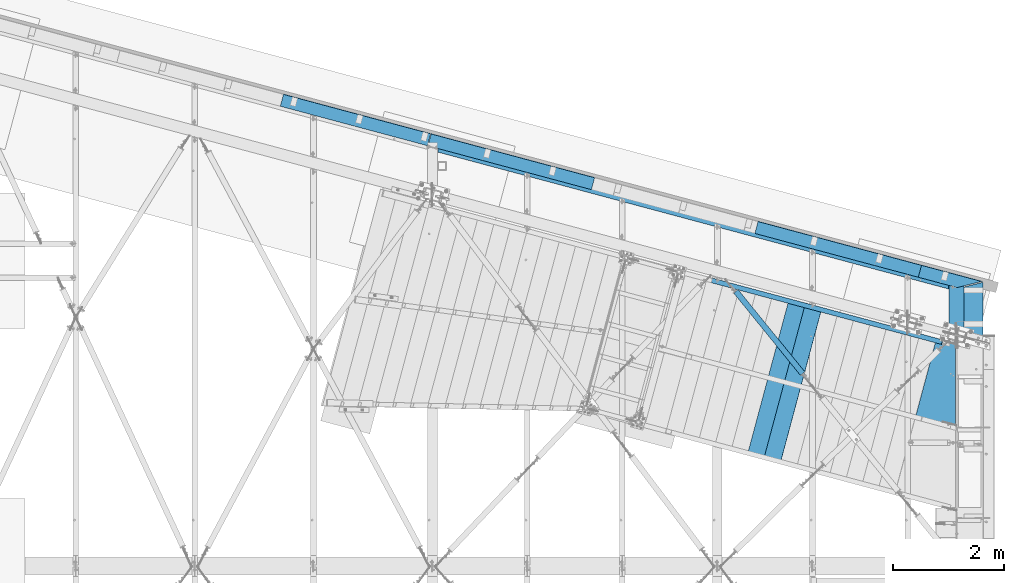
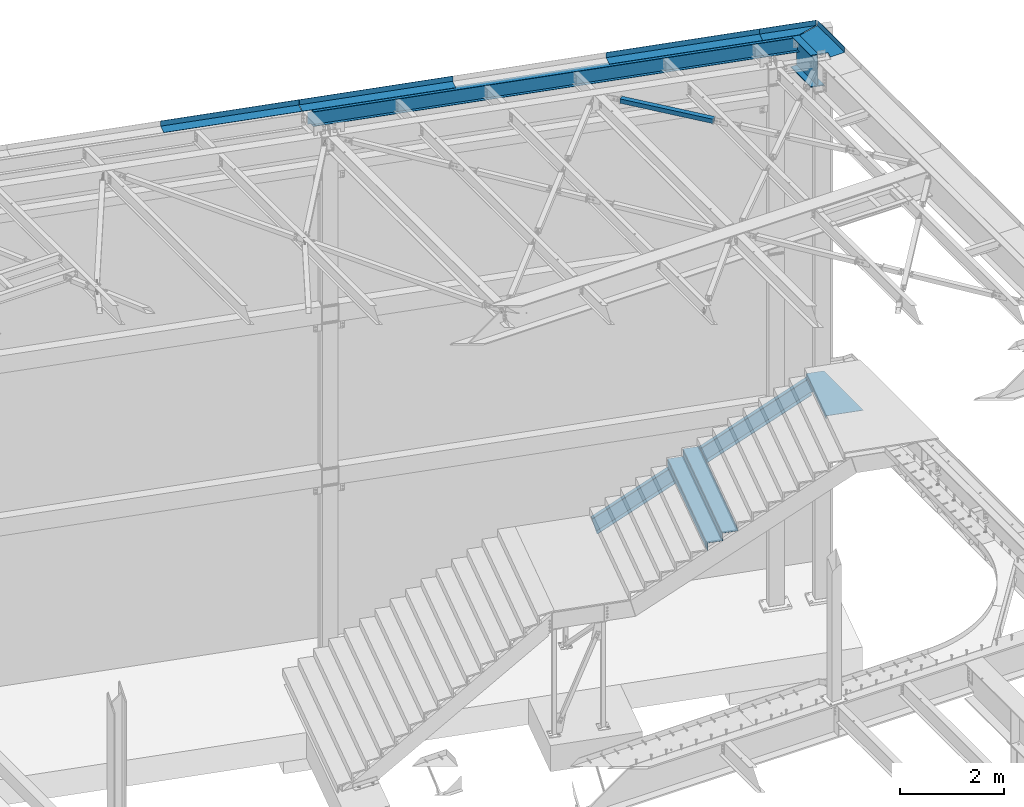
# One storey, part 1175 of 1763: 11 beams, 1 member, 6 elements without a shape of their own.
"""IFC2X3 building model written with IfcOpenShell, lengths in millimetres."""

from ifc_helpers import new_model, si_unit, frame, origin_with_axes, place, context, subcontext, project, spatial, faceted_brep, material, type_object, element, aggregate, save


model = new_model("IFC2X3")

# Units and contexts
model_context = context("Model", 3, precision=1e-05, world=origin_with_axes())
body_context = subcontext(model_context, "Body", "Model", "MODEL_VIEW")
ifc_project = project(units=[si_unit("LENGTHUNIT", "METRE", prefix="MILLI"), si_unit("AREAUNIT", "SQUARE_METRE"), si_unit("VOLUMEUNIT", "CUBIC_METRE"), si_unit("MASSUNIT", "GRAM", prefix="KILO"), si_unit("TIMEUNIT", "SECOND"), si_unit("PLANEANGLEUNIT", "RADIAN"), si_unit("SOLIDANGLEUNIT", "STERADIAN"), si_unit("THERMODYNAMICTEMPERATUREUNIT", "DEGREE_CELSIUS"), si_unit("LUMINOUSINTENSITYUNIT", "LUMEN")], contexts=[model_context])

# Site, building, storey
site_placement = place(None, origin_with_axes())
site = spatial("IfcSite", under=ifc_project, at=site_placement, CompositionType="ELEMENT")
building_placement = place(site_placement, origin_with_axes())
building = spatial("IfcBuilding", under=site, at=building_placement, Name="Undefined", CompositionType="ELEMENT")
storey_placement = place(building_placement, origin_with_axes())
storey = spatial("IfcBuildingStorey", under=building, at=storey_placement, Name="Undefined", CompositionType="ELEMENT", Elevation=0.0)

# Assembly, beam
assembly_1_placement = place(storey_placement, origin_with_axes())
assembly_1 = element("IfcElementAssembly", 1, at=assembly_1_placement, inside=storey, Name="BENT_PLATE", AssemblyPlace="NOTDEFINED", PredefinedType="RIGID_FRAME")
ifc_material_1 = material(Name="STEEL/A36")
beam_type_1 = type_object("IfcBeamType", PredefinedType="NOTDEFINED")
beam_1_placement = place(assembly_1_placement, frame((-20623.570463063, 60669.7976540184, 5251.44988278029), z_axis=(-0.258865912030778, -0.965913267114844, 3.00823476209188e-08), x_axis=(0.0, 0.0, -1.0)))
beam_1 = element("IfcBeam", 2, at=beam_1_placement, type_object=beam_type_1, material=ifc_material_1, Name="BENT_PLATE", context=body_context, shape_type="Brep", body=[
    faceted_brep([(57.6506588334341, -1650.94322731794, 733.41037240727), (47.6245708971892, -1650.94377090204, 733.410372253653), (47.6251633835427, -1650.9296699886, -733.439627678781), (57.6501641560826, -1650.9302135683, -733.439627534848), (121.443393857227, -1650.93021355403, -733.439649048218), (121.443888534568, -1650.94322730369, 733.410350893893), (121.443393855133, -1641.40521355441, -733.43956454334), (121.443888532473, -1641.41822730406, 733.410435398764), (57.650164153988, -1641.40521356867, -733.439543029977), (57.1501641539899, -1641.40466998691, -733.439539326588), (57.1495716676363, -1641.41877090035, 733.410460605854), (57.6506588313387, -1641.41822731832, 733.410456912134), (57.1496311080928, -906.560219858533, 733.416980199065), (47.6246311080931, -906.560220968502, 733.416976351727), (47.6251917954878, -1299.67460055151, -733.436511378146), (57.1501917954874, -1299.67459944154, -733.436507530809)], [[[0, 1, 2, 3, 4, 5]], [[5, 4, 6, 7]], [[8, 9, 10, 11, 7, 6]], [[1, 0, 5, 7, 11, 10, 12, 13]], [[2, 1, 13, 14]], [[9, 8, 6, 4, 3, 2, 14, 15]], [[10, 9, 15, 12]], [[14, 13, 12, 15]]]),
])
aggregate(assembly_1, [beam_1])

assembly_2_placement = place(storey_placement, origin_with_axes())
assembly_2 = element("IfcElementAssembly", 3, at=assembly_2_placement, inside=storey, Name="H. BRACE", AssemblyPlace="NOTDEFINED", PredefinedType="RIGID_FRAME")
ifc_material_2 = material()
beam_type_2 = type_object("IfcBeamType", Name="HSS4X4X3/8", PredefinedType="NOTDEFINED")
beam_2_placement = place(assembly_2_placement, frame((-24264.6496174484, 60949.8198631699, 12371.3875), z_axis=(0.0, 0.0, 1.0), x_axis=(-0.630211709758953, 0.776423338702989, 0.0)))
beam_2 = element("IfcBeam", 4, at=beam_2_placement, type_object=beam_type_2, material=ifc_material_2, Name="H. BRACE", ObjectType="HSS4X4X3/8", context=body_context, shape_type="Brep", body=[
    faceted_brep([(281.348620558478, 41.2749999993139, -41.2749999999996), (281.348620558667, -41.2750000006235, -41.2749999999996), (2189.29465645863, -41.2750000050546, -41.2749999999996), (2189.29465645843, 41.2749999948828, -41.2749999999996), (281.348620558667, -41.2750000006235, 41.2749999999996), (2189.29465645863, -41.2750000050546, 41.2749999999996), (281.348620558478, 41.2749999993139, 41.2749999999996), (2189.29465645843, 41.2749999948828, 41.2749999999996), (281.348620558456, 50.7999999993044, -50.7999999999993), (281.348620558456, 50.7999999993044, 50.7999999999993), (2189.29465645842, 50.7999999948806, 50.7999999999993), (2189.29465645842, 50.7999999948806, -50.7999999999993), (281.348620558689, -50.8000000006214, 50.7999999999993), (2189.29465645865, -50.8000000050415, 50.7999999999993), (281.348620558689, -50.8000000006214, -50.7999999999993), (2189.29465645865, -50.8000000050415, -50.7999999999993)], [[[0, 1, 2, 3]], [[1, 4, 5, 2]], [[4, 6, 7, 5]], [[6, 0, 3, 7]], [[8, 9, 10, 11]], [[9, 12, 13, 10]], [[12, 14, 15, 13]], [[14, 8, 11, 15]], [[13, 15, 11, 10], [5, 7, 3, 2]], [[14, 12, 9, 8], [6, 4, 1, 0]]]),
])
aggregate(assembly_2, [beam_2])

assembly_3_placement = place(storey_placement, origin_with_axes())
assembly_3 = element("IfcElementAssembly", 5, at=assembly_3_placement, inside=storey, Name="BEAM", AssemblyPlace="NOTDEFINED", PredefinedType="RIGID_FRAME")
ifc_material_3 = material(Name="STEEL/A992")
beam_type_3 = type_object("IfcBeamType", Name="W14X22", PredefinedType="NOTDEFINED")
beam_3_placement = place(assembly_3_placement, frame((-31117.2521174484, 65250.3763135178, 12271.375), z_axis=(0.0, 0.0, 1.0), x_axis=(0.965925826295336, -0.25881904507913, 0.0)))
beam_3 = element("IfcBeam", 6, at=beam_3_placement, type_object=beam_type_3, material=ifc_material_3, Name="BEAM", ObjectType="W14X22", context=body_context, shape_type="Brep", body=[
    faceted_brep([(25.5084291125531, -3.17499999995198, -142.874999999674), (25.5084291125531, 3.17500000006112, -142.874999999678), (96.1209962971625, 3.17500000019936, -142.874999999793), (97.8224736689081, -3.17499999981374, -142.874999999793), (101.152520857038, 3.17500000021391, -143.841729922387), (102.853998228791, -3.17499999981374, -143.841729922387), (105.418041413563, 3.17500000021391, -146.594743822867), (107.119518785308, -3.17499999979918, -146.594743822867), (108.268171129035, 3.17500000022847, -150.714920291017), (109.969648500781, -3.17499999979191, -150.714920291017), (109.269003590765, 3.17500000022119, -155.574999809058), (110.970480962511, -3.17499999979191, -155.574999809058), (127.134515994061, -63.4999999999491, -166.6875), (110.970480962176, -3.17499999978463, -166.6875), (109.269003590394, 3.17500000022847, -166.6875), (93.1049685585167, 63.5000000003856, -166.6875), (93.1049685585167, 63.5000000003856, -174.625), (127.134515994061, -63.4999999999491, -174.625), (9613.90070710065, 63.5000000184446, 166.6875), (9630.06474213253, 3.17500001828739, 166.6875), (109.269003591246, 3.17500000022847, 166.6875), (93.1049685593607, 63.5000000003856, 166.6875), (97.8224736687698, -3.17499999982101, 139.699999999804), (96.1209962970315, 3.17500000019936, 139.699999999804), (25.5084291125531, 3.17500000006112, 139.699999999919), (25.5084291125531, -3.17499999995198, 139.699999999923), (102.85399822866, -3.17499999980646, 140.666729922386), (101.152520856922, 3.17500000020664, 140.666729922386), (107.119518785199, -3.17499999979191, 143.419743822862), (105.418041413453, 3.17500000022119, 143.419743822862), (109.969648500686, -3.17499999979918, 147.539920291019), (108.268171128933, 3.17500000022119, 147.539920291019), (110.970480962424, -3.17499999979191, 152.399999809069), (109.269003590678, 3.17500000022119, 152.399999809069), (9647.93025453619, -63.4999999818901, 174.625), (9613.90070710065, 63.5000000184446, 174.625), (93.1049685593607, 63.5000000003856, 174.625), (127.134515994905, -63.4999999999491, 174.625), (9647.93025453619, -63.4999999818901, 166.6875), (127.134515994905, -63.4999999999491, 166.6875), (9631.76621950431, -3.17499998173298, 166.6875), (110.97048096302, -3.17499999978463, 166.6875), (9631.76621950499, -3.17499998174026, 141.287499820201), (9630.06474213324, 3.17500001828012, 141.287499820201), (9632.76705196672, -3.17499998173298, 136.427420302154), (9631.06557459498, 3.17500001828739, 136.427420302154), (9635.6171816822, -3.1749999817257, 132.307243834), (9633.91570431045, 3.17500001828739, 132.307243834), (9639.88270223873, -3.17499998171843, 129.554229933523), (9638.18122486698, 3.17500001829467, 129.554229933523), (9644.91422679861, -3.17499998170388, 128.587500010935), (9643.21274942686, 3.17500001830922, 128.587500010935), (9761.60279988415, -3.1749999814856, 128.587500010935), (9759.9013225124, 3.1750000185275, 128.587500010935), (9761.60279988415, -3.1749999814856, -166.6875), (9777.76683491575, -63.49999998165, -166.6875), (9777.76683491575, -63.49999998165, -174.625), (9743.7372874808, 63.5000000186919, -174.625), (9743.7372874808, 63.5000000186919, -166.6875), (9759.9013225124, 3.1750000185275, -166.6875)], [[[0, 1, 2, 3]], [[3, 2, 4, 5]], [[5, 4, 6, 7]], [[7, 6, 8, 9]], [[9, 8, 10, 11]], [[12, 13, 11, 10, 14, 15, 16, 17]], [[18, 19, 20, 21]], [[22, 23, 24, 25]], [[26, 27, 23, 22]], [[28, 29, 27, 26]], [[30, 31, 29, 28]], [[32, 33, 31, 30]], [[34, 35, 36, 37]], [[38, 34, 37, 39]], [[40, 38, 39, 41]], [[37, 36, 21, 20, 33, 32, 41, 39]], [[35, 18, 21, 36]], [[34, 38, 40, 42, 43, 19, 18, 35]], [[44, 45, 43, 42]], [[46, 47, 45, 44]], [[48, 49, 47, 46]], [[50, 51, 49, 48]], [[52, 53, 51, 50]], [[54, 55, 56, 57, 58, 59, 53, 52]], [[56, 55, 12, 17]], [[57, 56, 17, 16]], [[58, 57, 16, 15]], [[59, 58, 15, 14]], [[6, 4, 2, 1, 24, 23, 27, 29, 31, 33, 20, 19, 43, 45, 47, 49, 51, 53, 59, 14, 10, 8]], [[25, 24, 1, 0]], [[54, 52, 50, 48, 46, 44, 42, 40, 41, 32, 30, 28, 26, 22, 25, 0, 3, 5, 7, 9, 11, 13]], [[55, 54, 13, 12]]]),
])

assembly_4_placement = place(storey_placement, origin_with_axes())
assembly_4 = element("IfcElementAssembly", 7, at=assembly_4_placement, inside=storey, Name="BEAM", AssemblyPlace="NOTDEFINED", PredefinedType="RIGID_FRAME")
beam_type_4 = type_object("IfcBeamType", PredefinedType="NOTDEFINED")
beam_4_placement = place(assembly_4_placement, frame((-32525.426175196, 65627.6954150612, 12449.175), z_axis=(-0.965925827679309, 0.258819039914073, 0.0), x_axis=(0.258819045079128, 0.965925826295336, 0.0)))
beam_4 = element("IfcBeam", 8, at=beam_4_placement, type_object=beam_type_4, material=ifc_material_1, Name="BENT_PLATE", context=body_context, shape_type="Brep", body=[
    faceted_brep([(-1.38752511702478e-08, -3.17499999999927, -1372.58549999819), (1.38898030854762e-08, -3.17499999999927, 1372.5854999982), (1.38898030854762e-08, 3.17499999999927, 1372.5854999982), (-1.38752511702478e-08, 3.17499999999927, -1372.58549999819), (228.599995019147, 3.17499999999745, 1372.58549999529), (228.599994931385, 3.17499999999745, -1372.58550000109), (222.249994931357, -3.17500000000109, -1372.58550000101), (222.249995019134, -3.17500000000109, 1372.58549999537), (228.599994989214, -123.82500003836, 1372.58549999258), (228.599994961318, -123.824999978362, -1372.5855000038), (222.249994989194, -123.82500003836, 1372.58549999267), (222.249994961297, -123.824999978362, -1372.58550000371)], [[[0, 1, 2, 3]], [[3, 2, 4, 5]], [[1, 0, 6, 7]], [[5, 4, 8, 9]], [[4, 2, 1, 7, 10, 8]], [[7, 6, 11, 10]], [[6, 0, 3, 5, 9, 11]], [[10, 11, 9, 8]]]),
])
aggregate(assembly_4, [beam_4])

# Beam
beam_5_placement = place(assembly_3_placement, frame((-29718.6799716604, 64875.6300365378, 12449.175), z_axis=(-0.965925827679309, 0.258819039914073, 0.0), x_axis=(0.258819045079128, 0.965925826295336, 0.0)))
beam_5 = element("IfcBeam", 9, at=beam_5_placement, type_object=beam_type_4, material=ifc_material_1, Name="BENT_PLATE", context=body_context, shape_type="Brep", body=[
    faceted_brep([(0.0, -3.17499999999927, -1523.99999999999), (0.0, -3.17499999999927, 1524.0), (0.0, 3.17499999999927, 1524.0), (0.0, 3.17499999999927, -1523.99999999999), (228.599995165183, 3.17499993969795, 1523.99999998704), (228.599994834185, 3.17499994154787, -1524.00000000063), (222.249995293445, -3.17500005680085, -1524.00000000046), (222.249995624443, -3.17500005865077, 1523.99999998722), (228.599994977769, -123.824999999819, 1524.000000004), (228.599994986405, -123.824999999819, -1524.00000000269), (222.249994977741, -123.824999999819, 1524.00000000397), (222.249994986378, -123.824999999819, -1524.00000000271)], [[[0, 1, 2, 3]], [[3, 2, 4, 5]], [[1, 0, 6, 7]], [[5, 4, 8, 9]], [[4, 2, 1, 7, 10, 8]], [[7, 6, 11, 10]], [[6, 0, 3, 5, 9, 11]], [[10, 11, 9, 8]]]),
])

beam_6_placement = place(assembly_3_placement, frame((-21808.4801090702, 62756.098371606, 12449.175), z_axis=(-0.965925827679309, 0.258819039914073, 0.0), x_axis=(0.258819045079128, 0.965925826295336, 0.0)))
beam_6 = element("IfcBeam", 10, at=beam_6_placement, type_object=beam_type_4, material=ifc_material_1, Name="BENT_PLATE", context=body_context, shape_type="Brep", body=[
    faceted_brep([(228.59999498049, 3.17499999999927, 569.241499998789), (-3.34694050252438e-10, 3.17499999999927, 569.24149999924), (-3.34694050252438e-10, -3.17499999999927, 569.24149999924), (222.24999498047, -3.17499999999927, 569.241499998803), (222.249994979131, -123.825000004876, 569.241499998505), (228.599994979151, -123.825000004876, 569.241499998483), (228.599994979755, -123.825000002138, -564.310996623106), (228.599994978409, 3.17499999999927, -564.310996620698), (8.00355337560177e-11, 3.17499999999927, -151.54164795929), (8.00355337560177e-11, -3.17499999999927, -151.54164795929), (222.249994978418, -3.17499999999927, -552.845181128236), (222.249994979727, -123.825000002165, -552.8451811306)], [[[0, 1, 2, 3, 4, 5]], [[0, 5, 6, 7]], [[1, 0, 7, 8]], [[2, 1, 8, 9]], [[3, 2, 9, 10]], [[4, 3, 10, 11]], [[5, 4, 11, 6]], [[10, 9, 8, 7, 6, 11]]]),
])

beam_7_placement = place(assembly_3_placement, frame((-23830.3961345848, 63297.8691377512, 12449.175), z_axis=(-0.965925827679309, 0.258819039914073, 0.0), x_axis=(0.258819045079128, 0.965925826295336, 0.0)))
beam_7 = element("IfcBeam", 11, at=beam_7_placement, type_object=beam_type_4, material=ifc_material_1, Name="BENT_PLATE", context=body_context, shape_type="Brep", body=[
    faceted_brep([(0.0, -3.17499999999927, -1523.99999999999), (0.0, -3.17499999999927, 1524.0), (0.0, 3.17499999999927, 1524.0), (0.0, 3.17499999999927, -1523.99999999999), (228.599995165183, 3.17499993969795, 1523.99999998704), (228.599994834185, 3.17499994154787, -1524.00000000063), (222.249995293445, -3.17500005680085, -1524.00000000046), (222.249995624443, -3.17500005865077, 1523.99999998722), (228.599994977769, -123.824999999819, 1524.000000004), (228.599994986405, -123.824999999819, -1524.00000000269), (222.249994977741, -123.824999999819, 1524.00000000397), (222.249994986378, -123.824999999819, -1524.00000000271)], [[[0, 1, 2, 3]], [[3, 2, 4, 5]], [[1, 0, 6, 7]], [[5, 4, 8, 9]], [[4, 2, 1, 7, 10, 8]], [[7, 6, 11, 10]], [[6, 0, 3, 5, 9, 11]], [[10, 11, 9, 8]]]),
])

aggregate(assembly_3, [beam_5, beam_6, beam_7, beam_3])

# Assembly, beam
assembly_5_placement = place(storey_placement, origin_with_axes())
assembly_5 = element("IfcElementAssembly", 12, at=assembly_5_placement, inside=storey, Name="BEAM", AssemblyPlace="NOTDEFINED", PredefinedType="RIGID_FRAME")
beam_type_5 = type_object("IfcBeamType", PredefinedType="NOTDEFINED")
beam_8_placement = place(assembly_5_placement, frame((-21657.3396174484, 62294.5421055503, 12449.1750000081), z_axis=(0.0, -1.0, 0.0), x_axis=(1.0, 0.0, 0.0)))
beam_8 = element("IfcBeam", 13, at=beam_8_placement, type_object=beam_type_5, material=ifc_material_1, Name="BENT_PLATE", context=body_context, shape_type="Brep", body=[
    faceted_brep([(182.720654144166, -3.17500000807013, 370.866916913903), (182.720654144166, 3.17499999999927, 370.866916913903), (0.0, 3.17499999999927, 321.897562840262), (0.0, -3.17499999999927, 321.897562840262), (142.803059551425, -3.17499999999927, 519.8125), (142.803059551425, 3.17499999999927, 519.8125), (466.725006103516, -3.17499999999927, 519.8125), (466.725006103516, 123.825000000001, 519.8125), (460.375006103517, 123.825000000001, 519.8125), (460.375006103517, 3.17499999999927, 519.8125), (466.725006103516, -3.17499999999927, -519.8125), (466.725006103516, 123.825000000001, -519.8125), (460.375006103517, 123.825000000001, -518.28232777401), (460.375006103517, 3.17499999999927, -518.28232777401), (0.0, 3.17499999999927, -403.680835359948), (0.0, -3.17499999999927, -403.680835359948)], [[[0, 1, 2, 3]], [[4, 5, 1, 0]], [[6, 7, 8, 9, 5, 4]], [[7, 6, 10, 11]], [[8, 7, 11, 12]], [[9, 8, 12, 13]], [[2, 1, 5, 9, 13, 14]], [[3, 2, 14, 15]], [[6, 4, 0, 3, 15, 10]], [[14, 13, 12, 11, 10, 15]]]),
])

# Assembly, member
assembly_6_placement = place(storey_placement, origin_with_axes())
assembly_6 = element("IfcElementAssembly", 14, at=assembly_6_placement, inside=storey, Name="STRINGER", AssemblyPlace="NOTDEFINED", PredefinedType="RIGID_FRAME")
member_type = type_object("IfcMemberType", Name="C15X33.9", PredefinedType="NOTDEFINED")
member_placement = place(assembly_6_placement, frame((-21831.0065570277, 61708.2782716226, 5029.75011938), z_axis=(0.486695708763338, -0.13043503320458, -0.863778900636194), x_axis=(-0.834335499956352, 0.223602912988303, -0.50387102597364)))
member = element("IfcMember", 15, at=member_placement, type_object=member_type, material=ifc_material_1, Name="STRINGER", ObjectType="C15X33.9", context=body_context, shape_type="Brep", body=[
    faceted_brep([(5093.86808868585, -40.0966168740488, -181.305096367927), (5093.86808870259, 33.3374999864391, -181.30509636792), (5097.17557359672, 33.33749998641, -169.070972498997), (5184.86027757211, -42.862500014875, 190.500000000771), (5191.54668042265, -42.8625000148677, 181.765892500778), (5191.89944326302, -40.0966168751911, 181.30509636971), (5191.89944327977, 33.3374999852967, 181.305096369717), (5184.86027759157, 42.532403616402, 190.500000000782), (5081.85725439498, 42.5324036176025, -190.499999998985), (5081.51530759058, 42.8624999865206, -190.499999998981), (5184.51833078719, 42.86249998532, 190.500000000782), (5188.59195838564, 33.3374999853477, 169.070972500795), (5093.2661741679, -42.8625000137181, -181.765892498999), (5081.85725437552, -42.8625000136672, -190.499999998996), (9.52499993769015, -42.8624999996755, -190.499999999876), (2.8385970806994, -42.8624999996682, -181.765892499883), (2.48583423947275, -40.0966168460727, -181.305096366494), (2.48583425621473, 33.3375000004962, -181.30509636649), (9.52499995716062, 42.532403633908, -190.499999999869), (5.79331913747228, 33.3375000004598, -169.070972499889), (86.9230119693748, 33.3374999995067, 131.021317260747), (97.2097035880579, 33.3374999993976, 169.070972499907), (103.003022770456, 33.3374999986409, 190.499999999894), (112.8699695746, 42.8624999993117, 190.499999999894), (9.86694675921899, 42.8625000005195, -190.499999999869), (252.228013597647, 33.337499998961, 169.070972499932), (252.228013597676, 33.3374999977386, 190.499999979631), (252.228013597967, -42.862500002404, 190.499999999534), (252.228013597956, -42.8625000012398, 181.765892499916)], [[[0, 1, 2]], [[3, 4, 5, 6, 7]], [[1, 8, 9, 10, 7, 6, 11, 2]], [[0, 12, 13, 8, 1]], [[14, 15, 16, 17, 18]], [[19, 20, 21, 22, 23, 24, 18, 17]], [[22, 21, 25, 26]], [[27, 26, 25, 28]], [[27, 28, 4, 3]], [[28, 25, 11, 5, 4]], [[2, 19, 16, 15, 12, 0]], [[15, 14, 13, 12]], [[13, 14, 18, 24, 9, 8]], [[24, 23, 10, 9]], [[5, 11, 6]], [[25, 21, 20, 19, 2, 11]], [[19, 17, 16]], [[10, 23, 22, 26, 27, 3, 7]]]),
])

# Beam
beam_type_6 = type_object("IfcBeamType", Name="W30X90", PredefinedType="NOTDEFINED")
beam_9_placement = place(assembly_5_placement, frame((-21670.0396174484, 61857.7142211422, 12071.35), z_axis=(0.0, 0.0, 1.0), x_axis=(0.0, 1.0, 0.0)))
beam_9 = element("IfcBeam", 16, at=beam_9_placement, type_object=beam_type_6, material=ifc_material_3, Name="BEAM", ObjectType="W30X90", context=body_context, shape_type="Brep", body=[
    faceted_brep([(125.913804920681, 6.34999999999854, -358.775), (122.510189710942, -6.34999999999854, -358.775), (142.091642277403, -6.34999999999854, -358.775), (145.495257482522, 6.34999999999854, -358.775), (153.231514021696, -6.34999999999854, -349.250000017137), (156.635129226815, 6.34999999999854, -349.250000025268), (156.038440255397, -6.34999999999854, -346.849975395311), (159.442055460517, 6.34999999999854, -346.849975403444), (157.443157200156, -6.34999999999854, -345.365293715493), (160.846772405275, 6.34999999999854, -345.365293723624), (158.493804238766, -6.34999999999854, -343.62880521505), (161.897419443892, 6.34999999999854, -343.628805223181), (159.143535047639, -6.34999999999854, -341.717936564621), (162.547150252765, 6.34999999999854, -341.717936572752), (152.905861028063, 6.34999999999854, -330.200000027971), (149.502245822943, -6.34999999999854, -330.20000001984), (116.631798419519, -6.34999999999854, -330.200000405674), (120.035413624639, 6.34999999999854, -330.200000413806), (156.679553328358, 6.34999999999854, -330.92504736714), (153.275938123239, -6.34999999999854, -330.925047359009), (159.87873523499, 6.34999999999854, -332.98980759456), (156.475120029871, -6.34999999999854, -332.989807586428), (162.016360330425, 6.34999999999854, -336.079939700187), (158.612745125298, -6.34999999999854, -336.079939692056), (162.766994589168, 6.34999999999854, -339.717889717285), (159.363379384049, -6.34999999999854, -339.717889709154), (932.232303561796, -131.762500000001, 374.65), (932.232303561796, 131.762500000001, 374.65), (159.52450469655, 131.762500000001, 374.650000008056), (88.8994890945251, -131.762500000001, 374.65), (83.0210982686403, -131.762500000001, 358.775), (108.480942126807, -131.762500000001, 358.775), (932.232303561796, -131.762500000001, 358.775), (79.7343844080533, -131.762500000001, 358.775), (116.631798419236, -6.34999999999854, 358.775), (142.091642277403, -6.34999999999854, 358.775), (932.232303561796, -6.34999999999854, 358.775), (113.345084558729, -6.34999999999854, 358.775), (932.232303561796, -131.762500000001, -374.65), (932.232303561796, -131.762500000001, -358.775), (108.480942126807, -131.762500000001, -358.775), (88.8994895147989, -131.762500000001, -358.775), (79.7343844080533, -131.762500000001, -374.65), (932.232303561796, 131.762500000001, -374.65), (150.359399914545, 131.762500000001, -374.65), (179.105957633117, 131.762500000001, -358.774999297637), (932.232303561796, 131.762500000001, -358.775), (159.524505116824, 131.762500000001, -358.774999279374), (932.232303561796, 6.34999999999854, -358.775), (932.232303561796, 6.34999999999854, 358.775), (932.232303561796, 131.762500000001, 358.775), (932.232303561796, -6.34999999999854, -358.775), (179.105957633117, 131.762500000001, 358.775), (153.64611377495, 131.762500000001, 358.775), (150.359399914545, 131.762500000001, 358.775), (116.748699763863, 6.34999999999854, 358.775), (145.495257482522, 6.34999999999854, 358.774988175401), (120.035413624355, 6.34999999999854, 358.774987792742), (156.635129226815, 6.34999999999854, 349.250000015953), (153.231514021696, -6.34999999999854, 349.250000007822), (159.442055460517, 6.34999999999854, 346.849975394129), (156.038440255397, -6.34999999999854, 346.849975385996), (160.846772405275, 6.34999999999854, 345.365293714309), (157.443157200156, -6.34999999999854, 345.365293706178), (161.897419443892, 6.34999999999854, 343.628805213866), (158.493804238766, -6.34999999999854, 343.628805205735), (162.547150252765, 6.34999999999854, 341.717936563437), (159.143535047639, -6.34999999999854, 341.717936555306), (162.766994589168, 6.34999999999854, 339.71788970797), (159.363379384049, -6.34999999999854, 339.717889699839), (162.016360330425, 6.34999999999854, 336.079939690871), (158.612745125298, -6.34999999999854, 336.079939682741), (159.87873523499, 6.34999999999854, 332.989807585245), (156.475120029871, -6.34999999999854, 332.989807577113), (156.679553328358, 6.34999999999854, 330.925047357825), (153.275938123239, -6.34999999999854, 330.925047349694), (152.905861028063, 6.34999999999854, 330.200000018656), (149.502245822943, -6.34999999999854, 330.200000010525), (120.03541362437, 6.34999999999854, 330.200000404491), (116.631798419243, -6.34999999999854, 330.20000039636)], [[[0, 1, 2, 3]], [[3, 2, 4, 5]], [[5, 4, 6, 7]], [[7, 6, 8, 9]], [[9, 8, 10, 11]], [[11, 10, 12, 13]], [[14, 15, 16, 17]], [[18, 19, 15, 14]], [[20, 21, 19, 18]], [[22, 23, 21, 20]], [[24, 25, 23, 22]], [[13, 12, 25, 24]], [[26, 27, 28, 29]], [[30, 31, 32, 26, 29, 33]], [[34, 35, 36, 32, 31, 30, 33, 37]], [[38, 39, 40, 41, 42]], [[43, 38, 42, 44]], [[45, 46, 43, 44, 47]], [[48, 49, 50, 27, 26, 32, 36, 51, 39, 38, 43, 46]], [[27, 50, 52, 53, 54, 28]], [[33, 29, 28, 54, 55, 37]], [[53, 52, 50, 49, 56, 57, 55, 54]], [[37, 55, 57, 34]], [[56, 35, 34, 57]], [[58, 59, 35, 56]], [[60, 61, 59, 58]], [[62, 63, 61, 60]], [[64, 65, 63, 62]], [[66, 67, 65, 64]], [[68, 69, 67, 66]], [[70, 71, 69, 68]], [[72, 73, 71, 70]], [[74, 75, 73, 72]], [[76, 77, 75, 74]], [[78, 79, 77, 76]], [[79, 78, 17, 16]], [[10, 8, 6, 4, 2, 51, 36, 35, 59, 61, 63, 65, 67, 69, 71, 73, 75, 77, 79, 16, 15, 19, 21, 23, 25, 12]], [[40, 39, 51, 2, 1, 41]], [[47, 44, 42, 41, 1, 0]], [[3, 48, 46, 45, 47, 0]], [[20, 18, 14, 17, 78, 76, 74, 72, 70, 68, 66, 64, 62, 60, 58, 56, 49, 48, 3, 5, 7, 9, 11, 13, 24, 22]]]),
])

aggregate(assembly_5, [beam_8, beam_9])

beam_type_7 = type_object("IfcBeamType", PredefinedType="NOTDEFINED")
beam_10_placement = place(assembly_6_placement, frame((-24468.8503575877, 60947.6259576303, 3930.64997253453), z_axis=(-0.258865912030778, -0.965913267114844, 3.00823476209188e-08), x_axis=(0.0, 0.0, -1.0)))
beam_10 = element("IfcBeam", 17, at=beam_10_placement, type_object=beam_type_7, material=ifc_material_1, Name="BENT_PLATE", context=body_context, shape_type="Brep", body=[
    faceted_brep([(1.9117578631267e-09, -1.5875000009255, -1460.49999999993), (-1.18325260700658e-09, -1.58749999909924, 1460.49999999992), (-1.9117578631267e-09, 1.58750000090367, 1460.49999999991), (1.18234311230481e-09, 1.58749999907741, -1460.49999999993), (50.7999999972071, 1.58750001260341, 1460.50000000007), (50.800000002233, 1.58750001077715, -1460.49999999979), (47.6250000029295, -1.58749998995336, -1460.4999999998), (47.6249999979027, -1.58749998812709, 1460.50000000005), (50.8000000657603, -306.387503397986, 1460.50000000045), (50.8000000687034, -306.387503401733, -1460.49999999939), (47.6250000693999, -309.562503402434, -1460.4999999994), (47.6250000664559, -309.562503398687, 1460.50000000045), (222.250000065187, -306.387503360114, 1460.50000000094), (222.250000068131, -306.387503363934, -1460.49999999891), (222.250000065887, -309.562503360117, 1460.50000000094), (222.250000068831, -309.562503363937, -1460.4999999989)], [[[0, 1, 2, 3]], [[3, 2, 4, 5]], [[1, 0, 6, 7]], [[5, 4, 8, 9]], [[7, 6, 10, 11]], [[9, 8, 12, 13]], [[8, 4, 2, 1, 7, 11, 14, 12]], [[11, 10, 15, 14]], [[10, 6, 0, 3, 5, 9, 13, 15]], [[14, 15, 13, 12]]]),
])

beam_11_placement = place(assembly_6_placement, frame((-24763.2606374478, 61026.5282651166, 3752.85004577672), z_axis=(-0.258865912030778, -0.965913267114844, 3.00823476209188e-08), x_axis=(0.0, 0.0, -1.0)))
beam_11 = element("IfcBeam", 18, at=beam_11_placement, type_object=beam_type_7, material=ifc_material_1, Name="BENT_PLATE", context=body_context, shape_type="Brep", body=[
    faceted_brep([(1.9117578631267e-09, -1.5875000009255, -1460.49999999993), (-1.18325260700658e-09, -1.58749999909924, 1460.49999999992), (-1.9117578631267e-09, 1.58750000090367, 1460.49999999991), (1.18234311230481e-09, 1.58749999907741, -1460.49999999993), (50.7999999972071, 1.58750001260341, 1460.50000000007), (50.800000002233, 1.58750001077715, -1460.49999999979), (47.6250000029295, -1.58749998995336, -1460.4999999998), (47.6249999979027, -1.58749998812709, 1460.50000000005), (50.8000000657603, -306.387503397986, 1460.50000000045), (50.8000000687034, -306.387503401733, -1460.49999999939), (47.6250000693999, -309.562503402434, -1460.4999999994), (47.6250000664559, -309.562503398687, 1460.50000000045), (222.250000065187, -306.387503360114, 1460.50000000094), (222.250000068131, -306.387503363934, -1460.49999999891), (222.250000065887, -309.562503360117, 1460.50000000094), (222.250000068831, -309.562503363937, -1460.4999999989)], [[[0, 1, 2, 3]], [[3, 2, 4, 5]], [[1, 0, 6, 7]], [[5, 4, 8, 9]], [[7, 6, 10, 11]], [[9, 8, 12, 13]], [[8, 4, 2, 1, 7, 11, 14, 12]], [[11, 10, 15, 14]], [[10, 6, 0, 3, 5, 9, 13, 15]], [[14, 15, 13, 12]]]),
])

aggregate(assembly_6, [member, beam_10, beam_11])

save(model, "model.ifc")
